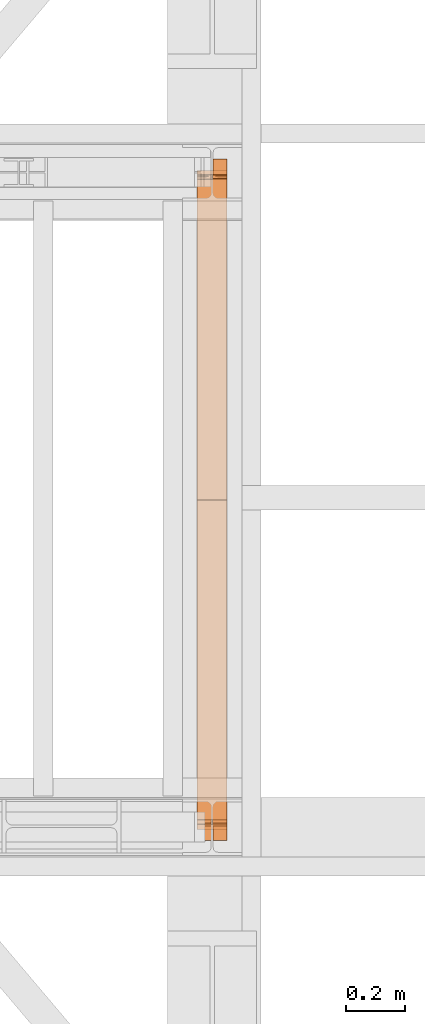
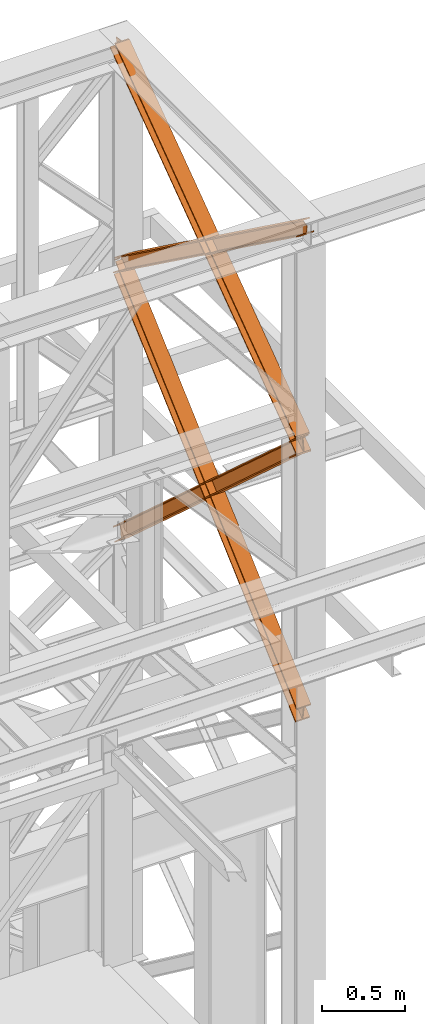
# One storey, part 184 of 208: 4 proxies.
"""IFC2X3 building model written with IfcOpenShell, lengths in millimetres."""

import ifcopenshell
import ifcopenshell.guid

model = None  # the IFC model being written
_history = None  # IfcOwnerHistory: only IFC2X3 demands one
_inside = {}  # id of a spatial element -> (the spatial element, [elements in it])
_under = {}  # id of a project, library or spatial element -> (it, [spatial elements below it])
_declared = {}  # id of a project -> (the project, [libraries it declares])
_typed = {}  # id of a type object -> (the type object, [elements of that type])
_made_of = {}  # id of a material, layer set ... -> (it, [elements and type objects made of it])


def new_model(schema):
    """Start an empty IFC model of exactly this schema.

    Asked for "IFC4X3", IfcOpenShell would pick the latest addendum, in which some entities
    have other attributes; the version numbers below select the first issue.
    IFC2X3 requires an IfcOwnerHistory on every rooted entity: one is made here for all.
    """
    global model, _history
    if schema == "IFC4X3":
        model = ifcopenshell.file(schema_version=(4, 3, 0, 0))
    else:
        model = ifcopenshell.file(schema=schema)
    _inside.clear()
    _under.clear()
    _declared.clear()
    _typed.clear()
    _made_of.clear()
    _history = None
    if model.schema == "IFC2X3":
        org = make("IfcOrganization", Name="unknown")
        user = make(
            "IfcPersonAndOrganization",
            ThePerson=make("IfcPerson", FamilyName="unknown"),
            TheOrganization=org,
        )
        app = make(
            "IfcApplication",
            ApplicationDeveloper=org,
            Version="unknown",
            ApplicationFullName="unknown",
            ApplicationIdentifier="unknown",
        )
        _history = make(
            "IfcOwnerHistory",
            OwningUser=user,
            OwningApplication=app,
            ChangeAction="ADDED",
            CreationDate=0,
        )
    return model


def make(cls, **values):
    """One entity of the class cls with the attributes given. An attribute that is None is left unset."""
    return model.create_entity(
        cls, **{name: value for name, value in values.items() if value is not None}
    )


def entity(cls, *values):
    """Any entity or typed value of the class cls, its attributes in the order of the schema. None: left unset."""
    e = model.create_entity(cls)
    for i, value in enumerate(values):
        if value is not None:
            e[i] = value
    return e


def rooted(cls, **values):
    """An entity with a GlobalId (a new one), such as an element, a storey or a relation."""
    return make(cls, GlobalId=ifcopenshell.guid.new(), OwnerHistory=_history, **values)


def si_unit(unit_type, name, prefix=None):
    """IfcSIUnit, for example si_unit("LENGTHUNIT", "METRE", prefix="MILLI")."""
    return make("IfcSIUnit", UnitType=unit_type, Prefix=prefix, Name=name)


def converted_unit(unit_type, name, factor, base, dimensions=None, offset=None):
    """IfcConversionBasedUnit, such as the inch: factor (a typed value) times the base unit."""
    return make(
        "IfcConversionBasedUnit"
        if offset is None
        else "IfcConversionBasedUnitWithOffset",
        ConversionOffset=offset,
        Dimensions=None
        if dimensions is None
        else entity("IfcDimensionalExponents", *dimensions),
        UnitType=unit_type,
        Name=name,
        ConversionFactor=make(
            "IfcMeasureWithUnit", ValueComponent=factor, UnitComponent=base
        ),
    )


def assignment(units):
    """IfcUnitAssignment: the units of a project."""
    return None if units is None else make("IfcUnitAssignment", Units=units)


def point(xyz):
    """IfcCartesianPoint."""
    return None if xyz is None else make("IfcCartesianPoint", Coordinates=xyz)


def direction(xyz):
    """IfcDirection."""
    return None if xyz is None else make("IfcDirection", DirectionRatios=xyz)


def frame(location, z_axis=None, x_axis=None):
    """IfcAxis2Placement3D, a coordinate frame: its origin and axes. An axis left out is left unset."""
    return make(
        "IfcAxis2Placement3D",
        Location=point(location),
        Axis=direction(z_axis),
        RefDirection=direction(x_axis),
    )


def origin():
    """The frame at (0, 0, 0) with its axes left unset."""
    return frame((0.0, 0.0, 0.0))


def origin_with_axes():
    """The frame at (0, 0, 0) with the z axis (0, 0, 1) and the x axis (1, 0, 0) written out."""
    return frame((0.0, 0.0, 0.0), z_axis=(0.0, 0.0, 1.0), x_axis=(1.0, 0.0, 0.0))


def place(relative_to, where):
    """IfcLocalPlacement: puts the frame where relative to a parent placement (None: the world)."""
    return make(
        "IfcLocalPlacement", PlacementRelTo=relative_to, RelativePlacement=where
    )


def context(
    kind, dimensions, precision=None, world=None, true_north=None, identifier=None
):
    """IfcGeometricRepresentationContext, for example the 3D "Model" context."""
    return make(
        "IfcGeometricRepresentationContext",
        ContextIdentifier=identifier,
        ContextType=kind,
        CoordinateSpaceDimension=dimensions,
        Precision=precision,
        WorldCoordinateSystem=world,
        TrueNorth=true_north,
    )


def subcontext(parent, identifier, kind, view, scale=None):
    """IfcGeometricRepresentationSubContext, for example "Body" below "Model"."""
    return make(
        "IfcGeometricRepresentationSubContext",
        ContextIdentifier=identifier,
        ContextType=kind,
        ParentContext=parent,
        TargetScale=scale,
        TargetView=view,
    )


def project(units=None, contexts=None):
    """IfcProject with its units and contexts."""
    return rooted(
        "IfcProject",
        Name="project",
        RepresentationContexts=contexts,
        UnitsInContext=assignment(units),
    )


def spatial(cls, under=None, at=None, **own):
    """A site, building, storey or space (cls), placed at a placement, below another one or the project."""
    s = rooted(cls, ObjectPlacement=at, **own)
    if under is not None:
        _under.setdefault(under.id(), (under, []))[1].append(s)
    return s


def faces_of(points, faces, orient=None, outer=None):
    """IfcFace entities. A face is a list of loops; a loop is a list of indices into points, from 0.

    orient and outer hold one flag for each loop. By default every Orientation is true, the
    first loop of a face is its IfcFaceOuterBound and the others are IfcFaceBound.
    """
    made = []
    for i, loops in enumerate(faces):
        bounds = []
        for j, loop in enumerate(loops):
            is_outer = j == 0 if outer is None else outer[i][j]
            bounds.append(
                make(
                    "IfcFaceOuterBound" if is_outer else "IfcFaceBound",
                    Bound=make("IfcPolyLoop", Polygon=[points[k] for k in loop]),
                    Orientation=True if orient is None else orient[i][j],
                )
            )
        made.append(make("IfcFace", Bounds=bounds))
    return made


def faceted_brep(points, faces, orient=None, outer=None, voids=None):
    """IfcFacetedBrep: a solid bounded by flat faces; with voids (closed shells), ...WithVoids."""
    shared = [point(p) for p in points]
    hull = make("IfcClosedShell", CfsFaces=faces_of(shared, faces, orient, outer))
    if voids is None:
        return make("IfcFacetedBrep", Outer=hull)
    return make(
        "IfcFacetedBrepWithVoids",
        Outer=hull,
        Voids=[
            make(cls, CfsFaces=faces_of(shared, fs, o, b)) for cls, fs, o, b in voids
        ],
    )


def shape(context_of_items, identifier, shape_type, items):
    """IfcShapeRepresentation: the items that make up one representation, for example the "Body"."""
    return make(
        "IfcShapeRepresentation",
        ContextOfItems=context_of_items,
        RepresentationIdentifier=identifier,
        RepresentationType=shape_type,
        Items=items,
    )


def made_of(thing, what):
    """Note that an element or type object is made of a material, layer set ...; save() writes the relation."""
    if what is not None:
        _made_of.setdefault(what.id(), (what, []))[1].append(thing)
    return thing


def element(
    cls,
    number,
    at=None,
    inside=None,
    cuts=None,
    type_object=None,
    material=None,
    context=None,
    identifier="Body",
    shape_type=None,
    held_by="IfcProductDefinitionShape",
    body=None,
    shapes=None,
    **own,
):
    """One element of the class cls, such as IfcWall. Its Tag is "e" and its number.

    at: its placement. inside: the storey or other place that contains it. cuts: it is an
    opening in that element (IfcRelVoidsElement). A single representation is given by context,
    identifier, shape_type and body (its items); several are given by shapes. held_by: the class
    of the entity that holds the representations. save() writes the other relations.
    """
    e = rooted(cls, Tag="e%d" % number, ObjectPlacement=at, **own)
    if body is not None:
        shapes = [shape(context, identifier, shape_type, body)]
    if shapes is not None:
        e.Representation = make(held_by, Representations=shapes)
    if inside is not None:
        _inside.setdefault(inside.id(), (inside, []))[1].append(e)
    if cuts is not None:
        rooted(
            "IfcRelVoidsElement", RelatingBuildingElement=cuts, RelatedOpeningElement=e
        )
    if type_object is not None:
        _typed.setdefault(type_object.id(), (type_object, []))[1].append(e)
    return made_of(e, material)


def aggregate(whole, parts):
    """IfcRelAggregates: a whole, such as a stair, and the parts it consists of."""
    return rooted("IfcRelAggregates", RelatingObject=whole, RelatedObjects=parts)


def save(model, path):
    """Write the relations noted so far, then the file.

    IfcRelAggregates (storeys below a building ...), IfcRelContainedInSpatialStructure (elements
    in a storey), IfcRelDefinesByType, IfcRelAssociatesMaterial and IfcRelDeclares: one each for
    every whole, place, type object, material and project.
    """
    for whole, parts in _under.values():
        aggregate(whole, parts)
    for where, things in _inside.values():
        rooted(
            "IfcRelContainedInSpatialStructure",
            RelatedElements=things,
            RelatingStructure=where,
        )
    for kind, things in _typed.values():
        rooted("IfcRelDefinesByType", RelatedObjects=things, RelatingType=kind)
    for what, things in _made_of.values():
        rooted("IfcRelAssociatesMaterial", RelatedObjects=things, RelatingMaterial=what)
    for by, libraries in _declared.values():
        rooted("IfcRelDeclares", RelatingContext=by, RelatedDefinitions=libraries)
    model.write(path)


model = new_model("IFC2X3")

# Units and contexts
model_context = context("Model", 3, precision=1e-05, world=origin())
plan_context = context("Plan", 3, precision=1e-05, world=origin())
body_context = subcontext(model_context, "Body", "Model", "MODEL_VIEW")
ifc_project = project(units=[si_unit("LENGTHUNIT", "METRE", prefix="MILLI"), converted_unit("PLANEANGLEUNIT", "DEGREE", entity("IfcPlaneAngleMeasure", 0.0174532925199433), si_unit("PLANEANGLEUNIT", "RADIAN"), dimensions=[0, 0, 0, 0, 0, 0, 0]), si_unit("AREAUNIT", "SQUARE_METRE"), si_unit("VOLUMEUNIT", "CUBIC_METRE")], contexts=[model_context, plan_context])

# Building, storey
building_placement = place(None, origin())
building = spatial("IfcBuilding", under=ifc_project, at=building_placement, CompositionType="COMPLEX")
storey_placement = place(building_placement, origin_with_axes())
storey = spatial("IfcBuildingStorey", under=building, at=storey_placement, Name="Geschoss", CompositionType="ELEMENT")

# Proxies
proxy_1_placement = place(storey_placement, frame((8742.709402308908, -16015.63876149258, 10682.68948145022), z_axis=(0.0, 0.0, 1.0), x_axis=(1.0, 0.0, 0.0)))
element("IfcBuildingElementProxy", 1, at=proxy_1_placement, inside=storey, context=body_context, shape_type="Brep", body=[
    faceted_brep([(100.0210796676656, 2245.689626284609, 118.5389832593155), (100.1143745484151, 56.20017042807194, 1708.580236273849), (100.1148393871226, 67.43957130666058, 1710.120789741106), (100.0220869572258, 2244.212677303514, 129.3143453983157), (100.0220869572258, 2244.212677303514, 129.3143453983157), (100.1148393871226, 67.43957130666058, 1710.120789741106), (0.1148394121519232, 67.45274636205431, 1710.122490249456), (0.02208754364073684, 2244.212677303513, 129.3256138365559), (0.02208754364073684, 2244.212677303513, 129.3256138365559), (0.1148394121519232, 67.45274636205431, 1710.122490249456), (0.1143745734407275, 56.21334548348023, 1708.581936782199), (0.02108025408597314, 2245.689626284609, 118.5502516975485), (0.02108025408597314, 2245.689626284609, 118.5502516975485), (0.1143745734407275, 56.21334548348023, 1708.581936782199), (47.61437456155181, 56.20708733215906, 1708.581129040735), (47.52107997553685, 2245.689626284611, 118.5448991893809), (47.52107997553685, 2245.689626284611, 118.5448991893809), (47.61437456155181, 56.20708733215906, 1708.581129040735), (47.61205046476789, 0.010082544398756, 1700.878361650326), (47.60701710203466, 7.394829104428936, 1647.001538883871), (47.51100702250551, 2260.459116064767, 10.79127802407129), (47.51100702250551, 2260.459116064767, 10.79127802407129), (47.60701710203466, 7.394829104428936, 1647.001538883871), (0.107017380585603, 7.394829104430755, 1647.006891392024), (0.01100730106008996, 2260.459116064769, 10.79663053222066), (0.01100730106008996, 2260.459116064769, 10.79663053222066), (0.107017380585603, 7.394829104430755, 1647.006891392024), (0.1060107062494353, 8.871778415476001, 1636.231526845748), (0.01000000000021828, 2261.936065039698, 0.02126843821861257), (0.01000000000021828, 2261.936065039698, 0.02126843821861257), (0.1060107062494353, 8.871778415476001, 1636.231526845748), (100.1060101198273, 8.871778415472363, 1636.220258407533), (100.0099994135744, 2261.936065039694, 0.01000000000021828), (100.0099994135744, 2261.936065039694, 0.01000000000021828), (100.1060101198273, 8.871778415472363, 1636.220258407533), (100.1070167941634, 7.394829104425298, 1646.995622953813), (100.0110067146379, 2260.459116064765, 10.78536209401318), (100.0110067146379, 2260.459116064765, 10.78536209401318), (100.1070167941634, 7.394829104425298, 1646.995622953813), (52.60701707271619, 7.394829104428936, 1647.000975461962), (52.51100699318704, 2260.459116064767, 10.79071460216255), (52.51100699318704, 2260.459116064767, 10.79071460216255), (52.60701707271619, 7.394829104428936, 1647.000975461962), (52.61205048734519, 0.01000000000021828, 1700.878355604191), (52.61437456030035, 56.20642857939311, 1708.581044015316), (52.52107994621292, 2245.689626284609, 118.5443357674758), (52.52107994621292, 2245.689626284609, 118.5443357674758), (52.61437456030035, 56.20642857939311, 1708.581044015316), (100.1143745484151, 56.20017042807194, 1708.580236273849), (100.0210796676656, 2245.689626284609, 118.5389832593155), (100.1143745484151, 56.20017042807194, 1708.580236273849), (52.61437456030035, 56.20642857939311, 1708.581044015316), (52.61205048734519, 0.01000000000021828, 1700.878355604191), (47.61205046476789, 0.010082544398756, 1700.878361650326), (47.61437456155181, 56.20708733215906, 1708.581129040735), (0.1143745734407275, 56.21334548348023, 1708.581936782199), (0.1148394121519232, 67.45274636205431, 1710.122490249456), (100.1148393871226, 67.43957130666058, 1710.120789741106), (47.61205046476789, 0.010082544398756, 1700.878361650326), (52.61205048734519, 0.01000000000021828, 1700.878355604191), (52.60701707271619, 7.394829104428936, 1647.000975461962), (100.1070167941634, 7.394829104425298, 1646.995622953813), (100.1060101198273, 8.871778415472363, 1636.220258407533), (0.1060107062494353, 8.871778415476001, 1636.231526845748), (0.107017380585603, 7.394829104430755, 1647.006891392024), (47.60701710203466, 7.394829104428936, 1647.001538883871), (100.0220869572258, 2244.212677303514, 129.3143453983157), (0.02208754364073684, 2244.212677303513, 129.3256138365559), (0.02108025408597314, 2245.689626284609, 118.5502516975485), (47.52107997553685, 2245.689626284611, 118.5448991893809), (47.51100702250551, 2260.459116064767, 10.79127802407129), (0.01100730106008996, 2260.459116064769, 10.79663053222066), (0.01000000000021828, 2261.936065039698, 0.02126843821861257), (100.0099994135744, 2261.936065039694, 0.01000000000021828), (100.0110067146379, 2260.459116064765, 10.78536209401318), (52.51100699318704, 2260.459116064767, 10.79071460216255), (52.52107994621292, 2245.689626284609, 118.5443357674758), (100.0210796676656, 2245.689626284609, 118.5389832593155)], [[[0, 1, 2, 3]], [[4, 5, 6, 7]], [[8, 9, 10, 11]], [[12, 13, 14, 15]], [[16, 17, 18, 19, 20]], [[21, 22, 23, 24]], [[25, 26, 27, 28]], [[29, 30, 31, 32]], [[33, 34, 35, 36]], [[37, 38, 39, 40]], [[41, 42, 43, 44, 45]], [[46, 47, 48, 49]], [[50, 51, 52, 53, 54, 55, 56, 57]], [[58, 59, 60, 61, 62, 63, 64, 65]], [[66, 67, 68, 69, 70, 71, 72, 73, 74, 75, 76, 77]]], orient=[[False], [False], [False], [False], [False], [False], [False], [False], [False], [False], [False], [False], [False], [False], [False]]),
])
proxy_2_placement = place(storey_placement, frame((8742.729181833696, -15971.44366069647, 10682.68296591904), z_axis=(0.0, 0.0, 1.0), x_axis=(1.0, 0.0, 0.0)))
element("IfcBuildingElementProxy", 2, at=proxy_2_placement, inside=storey, context=body_context, shape_type="Brep", body=[
    faceted_brep([(100.021793255235, 17.74853331263148, 129.3267546407205), (100.0912677831893, 2190.182945540866, 1706.987836358048), (100.090692227559, 2201.421092011329, 1705.446286432978), (100.0208104383455, 16.27032220023102, 118.5503583986774), (0.0217938701462117, 17.74853331263148, 129.3386776252864), (0.09126795233351004, 2190.169006714281, 1706.989636715169), (100.0912677831893, 2190.182945540866, 1706.987836358048), (100.021793255235, 17.74853331263148, 129.3267546407205), (0.02081105325669341, 16.27032220022738, 118.5622813832288), (0.09069239670134266, 2201.407153184735, 1705.448086790095), (0.09126795233351004, 2190.169006714281, 1706.989636715169), (0.0217938701462117, 17.74853331263148, 129.3386776252864), (47.52081076117429, 16.2703222002292, 118.5566179655598), (47.5906923163584, 2201.413774127363, 1705.447231620465), (0.09069239670134266, 2201.407153184735, 1705.448086790095), (0.02081105325669341, 16.27032220022738, 118.5622813832288), (47.51098253605596, 1.488211106367089, 10.79265576491343), (47.58304941302595, 2254.773823250514, 1647.169314498546), (47.58760831104883, 2261.634760381639, 1697.186647271237), (47.5906923163584, 2201.413774127363, 1705.447231620465), (47.52081076117429, 16.2703222002292, 118.5566179655598), (0.01098282814018603, 1.488211106363451, 10.79831918255331), (0.08304970511017018, 2254.773823250511, 1647.174977916204), (47.58304941302595, 2254.773823250514, 1647.169314498546), (47.51098253605596, 1.488211106367089, 10.79265576491343), (0.00999999999839929, 0.01000000000021828, 0.02192298452973773), (0.08206748974043876, 2253.295611815232, 1636.398579320261), (0.08304970511017018, 2254.773823250511, 1647.174977916204), (0.01098282814018603, 1.488211106363451, 10.79831918255331), (100.0099993850818, 0.01000000000567525, 0.01000000000021828), (100.0820668748274, 2253.29561181524, 1636.386656335728), (0.08206748974043876, 2253.295611815232, 1636.398579320261), (0.00999999999839929, 0.01000000000021828, 0.02192298452973773), (100.0109822132272, 1.488211106370727, 10.78639619803107), (100.0830490901899, 2254.773823250516, 1647.163054931671), (100.0820668748274, 2253.29561181524, 1636.386656335728), (100.0099993850818, 0.01000000000567525, 0.01000000000021828), (52.51098250530413, 1.48821110636527, 10.79205961566731), (52.58304938227775, 2254.773823250514, 1647.168718349318), (100.0830490901899, 2254.773823250516, 1647.163054931671), (100.0109822132272, 1.488211106370727, 10.78639619803107), (52.52081073042609, 16.27032220022738, 118.5560218163319), (52.59069230790192, 2201.414471068691, 1705.447141602608), (52.58760833413544, 2261.634841397497, 1697.186641740611), (52.58304938227775, 2254.773823250514, 1647.168718349318), (52.51098250530413, 1.48821110636527, 10.79205961566731), (100.0208104383455, 16.27032220023102, 118.5503583986774), (100.090692227559, 2201.421092011329, 1705.446286432978), (52.59069230790192, 2201.414471068691, 1705.447141602608), (52.52081073042609, 16.27032220022738, 118.5560218163319), (100.0912677831893, 2190.182945540866, 1706.987836358048), (0.09126795233351004, 2190.169006714281, 1706.989636715169), (0.09069239670134266, 2201.407153184735, 1705.448086790095), (47.5906923163584, 2201.413774127363, 1705.447231620465), (47.58760831104883, 2261.634760381639, 1697.186647271237), (52.58760833413544, 2261.634841397497, 1697.186641740611), (52.59069230790192, 2201.414471068691, 1705.447141602608), (100.090692227559, 2201.421092011329, 1705.446286432978), (47.58760831104883, 2261.634760381639, 1697.186647271237), (47.58304941302595, 2254.773823250514, 1647.169314498546), (0.08304970511017018, 2254.773823250511, 1647.174977916204), (0.08206748974043876, 2253.295611815232, 1636.398579320261), (100.0820668748274, 2253.29561181524, 1636.386656335728), (100.0830490901899, 2254.773823250516, 1647.163054931671), (52.58304938227775, 2254.773823250514, 1647.168718349318), (52.58760833413544, 2261.634841397497, 1697.186641740611), (100.0208104383455, 16.27032220023102, 118.5503583986774), (52.52081073042609, 16.27032220022738, 118.5560218163319), (52.51098250530413, 1.48821110636527, 10.79205961566731), (100.0109822132272, 1.488211106370727, 10.78639619803107), (100.0099993850818, 0.01000000000567525, 0.01000000000021828), (0.00999999999839929, 0.01000000000021828, 0.02192298452973773), (0.01098282814018603, 1.488211106363451, 10.79831918255331), (47.51098253605596, 1.488211106367089, 10.79265576491343), (47.52081076117429, 16.2703222002292, 118.5566179655598), (0.02081105325669341, 16.27032220022738, 118.5622813832288), (0.0217938701462117, 17.74853331263148, 129.3386776252864), (100.021793255235, 17.74853331263148, 129.3267546407205)], [[[0, 1, 2, 3]], [[4, 5, 6, 7]], [[8, 9, 10, 11]], [[12, 13, 14, 15]], [[16, 17, 18, 19, 20]], [[21, 22, 23, 24]], [[25, 26, 27, 28]], [[29, 30, 31, 32]], [[33, 34, 35, 36]], [[37, 38, 39, 40]], [[41, 42, 43, 44, 45]], [[46, 47, 48, 49]], [[50, 51, 52, 53, 54, 55, 56, 57]], [[58, 59, 60, 61, 62, 63, 64, 65]], [[66, 67, 68, 69, 70, 71, 72, 73, 74, 75, 76, 77]]], orient=[[False], [False], [False], [False], [False], [False], [False], [False], [False], [False], [False], [False], [False], [False], [False]]),
])
proxy_3_placement = place(storey_placement, frame((8742.676947659522, -15970.94025142175, 8709.664099392032), z_axis=(0.0, 0.0, 1.0), x_axis=(1.0, 0.0, 0.0)))
element("IfcBuildingElementProxy", 3, at=proxy_3_placement, inside=storey, context=body_context, shape_type="Brep", body=[
    faceted_brep([(100.0233874223195, 2202.524047252906, 1969.026231437971), (100.204135948361, 16.74193427489081, 0.02100513656296243), (100.2031119106669, 15.34760641933463, 9.331797992270367), (100.0223627570795, 2201.129719715085, 1978.337022171885), (0.02338802788472094, 2202.524047252906, 1969.015226301408), (0.2041365539262188, 16.74193427489081, 0.01000000000021828), (100.204135948361, 16.74193427489081, 0.02100513656296243), (100.0233874223195, 2202.524047252906, 1969.026231437971), (0.02236336264650163, 2201.129719715083, 1978.32601703533), (0.2031125162320677, 15.34760641933463, 9.320792855700347), (0.2041365539262188, 16.74193427489081, 0.01000000000021828), (0.02338802788472094, 2202.524047252906, 1969.015226301408), (47.52236307500243, 2201.129719715083, 1978.331244475192), (47.703112228588, 15.34760641933463, 9.326020295562557), (0.2031125162320677, 15.34760641933463, 9.320792855700347), (0.02236336264650163, 2201.129719715083, 1978.32601703533), (47.51211642258568, 2187.186444336861, 2071.439151814395), (47.69287186516885, 1.404327856926102, 102.4339488982641), (47.703112228588, 15.34760641933463, 9.326020295562557), (47.52236307500243, 2201.129719715083, 1978.331244475192), (0.0110594602265337, 2197.850904391578, 2081.040801967907), (0.01123343514518638, 2196.096022801514, 2079.459950003524), (29.30670605184969, 2196.096022801514, 2079.463174010305), (38.62248918838486, 2197.75725418804, 2080.960688188874), (38.72759933923771, 2197.85090439158, 2081.04506277602), (47.51211642258568, 2187.186444336861, 2071.439151814395), (0.0121167102297477, 2187.186444336861, 2071.433924374533), (0.1928721528147435, 1.404327856924283, 102.4287214583947), (47.69287186516885, 1.404327856926102, 102.4339488982641), (0.01000000000021828, 2196.807553171771, 2090.667763094707), (0.01020876990332909, 2194.701695263691, 2088.770740737438), (0.01123343514518638, 2196.096022801514, 2079.459950003524), (0.0110594602265337, 2197.850904391578, 2081.040801967907), (0.0121167102297477, 2187.186444336861, 2071.433924374533), (0.01109204498970939, 2185.792116799039, 2080.744715108447), (0.1918481178254297, 0.00999999999839929, 111.7395143232407), (0.1928721528147435, 1.404327856924283, 102.4287214583947), (100.0099993944386, 2196.80755317177, 2090.67876823127), (100.0102081643418, 2194.701695263691, 2088.781745874001), (71.80672165016404, 2194.701695263691, 2088.778642041782), (62.49088072881023, 2196.362926650216, 2090.274105784663), (61.99182992716487, 2196.80755317177, 2090.674584279774), (0.01109204498970939, 2185.792116799039, 2080.744715108447), (100.0110914394281, 2185.792116799039, 2080.755720245017), (100.1918475122639, 0.00999999999839929, 111.7505194598034), (0.1918481178254297, 0.00999999999839929, 111.7395143232407), (0.01020876990332909, 2194.701695263691, 2088.770740737438), (0.01000000000021828, 2196.807553171771, 2090.667763094707), (39.12153594998199, 2196.807553171771, 2090.672067372672), (38.62250061437408, 2196.362926650216, 2090.271479036817), (29.3067174778389, 2194.701695263691, 2088.773964858256), (100.0110588546631, 2197.85090439158, 2081.051807104463), (100.01123282958, 2196.096022801514, 2079.470955140079), (100.0102081643418, 2194.701695263691, 2088.781745874001), (100.0099993944386, 2196.80755317177, 2090.67876823127), (100.0110914394281, 2185.792116799039, 2080.755720245017), (100.0121161046682, 2187.186444336861, 2071.444929511088), (100.1928715472459, 1.404327856926102, 102.4397265949574), (100.1918475122639, 0.00999999999839929, 111.7505194598034), (52.5121163923086, 2187.186444336861, 2071.439702071226), (52.69287183489359, 1.404327856924283, 102.4344991550879), (100.1928715472459, 1.404327856926102, 102.4397265949574), (100.0121161046682, 2187.186444336861, 2071.444929511088), (71.80671022417482, 2196.096022801516, 2079.467851193831), (100.01123282958, 2196.096022801514, 2079.470955140079), (100.0110588546631, 2197.85090439158, 2081.051807104463), (62.38575589440734, 2197.85090439158, 2081.047666388475), (62.49086930282101, 2197.75725418804, 2080.963314936713), (52.52236304472172, 2201.129719715083, 1978.331794732023), (52.7031121983091, 15.34760641933463, 9.326570552393605), (52.69287183489359, 1.404327856924283, 102.4344991550879), (52.5121163923086, 2187.186444336861, 2071.439702071226), (100.0223627570795, 2201.129719715085, 1978.337022171885), (100.2031119106669, 15.34760641933463, 9.331797992270367), (52.7031121983091, 15.34760641933463, 9.326570552393605), (52.52236304472172, 2201.129719715083, 1978.331794732023), (62.38575589440734, 2197.85090439158, 2081.047666388475), (100.0110588546631, 2197.85090439158, 2081.051807104463), (100.0099993944386, 2196.80755317177, 2090.67876823127), (61.99182992716487, 2196.80755317177, 2090.674584279774), (39.12153594998199, 2196.807553171771, 2090.672067372672), (0.01000000000021828, 2196.807553171771, 2090.667763094707), (0.0110594602265337, 2197.850904391578, 2081.040801967907), (38.72759933923771, 2197.85090439158, 2081.04506277602), (62.49086930282101, 2197.75725418804, 2080.963314936713), (62.38575589440734, 2197.85090439158, 2081.047666388475), (61.99182992716487, 2196.80755317177, 2090.674584279774), (62.49088072881023, 2196.362926650216, 2090.274105784663), (62.49088072881023, 2196.362926650216, 2090.274105784663), (71.80672165016404, 2194.701695263691, 2088.778642041782), (71.80671022417482, 2196.096022801516, 2079.467851193831), (62.49086930282101, 2197.75725418804, 2080.963314936713), (71.80672165016404, 2194.701695263691, 2088.778642041782), (100.0102081643418, 2194.701695263691, 2088.781745874001), (100.01123282958, 2196.096022801514, 2079.470955140079), (71.80671022417482, 2196.096022801516, 2079.467851193831), (100.0223627570795, 2201.129719715085, 1978.337022171885), (52.52236304472172, 2201.129719715083, 1978.331794732023), (52.5121163923086, 2187.186444336861, 2071.439702071226), (100.0121161046682, 2187.186444336861, 2071.444929511088), (100.0110914394281, 2185.792116799039, 2080.755720245017), (0.01109204498970939, 2185.792116799039, 2080.744715108447), (0.0121167102297477, 2187.186444336861, 2071.433924374533), (47.51211642258568, 2187.186444336861, 2071.439151814395), (47.52236307500243, 2201.129719715083, 1978.331244475192), (0.02236336264650163, 2201.129719715083, 1978.32601703533), (0.02338802788472094, 2202.524047252906, 1969.015226301408), (100.0233874223195, 2202.524047252906, 1969.026231437971), (29.30670605184969, 2196.096022801514, 2079.463174010305), (0.01123343514518638, 2196.096022801514, 2079.459950003524), (0.01020876990332909, 2194.701695263691, 2088.770740737438), (29.3067174778389, 2194.701695263691, 2088.773964858256), (29.3067174778389, 2194.701695263691, 2088.773964858256), (38.62250061437408, 2196.362926650216, 2090.271479036817), (38.62248918838486, 2197.75725418804, 2080.960688188874), (29.30670605184969, 2196.096022801514, 2079.463174010305), (38.62250061437408, 2196.362926650216, 2090.271479036817), (39.12153594998199, 2196.807553171771, 2090.672067372672), (38.72759933923771, 2197.85090439158, 2081.04506277602), (38.62248918838486, 2197.75725418804, 2080.960688188874), (100.204135948361, 16.74193427489081, 0.02100513656296243), (0.2041365539262188, 16.74193427489081, 0.01000000000021828), (0.2031125162320677, 15.34760641933463, 9.320792855700347), (47.703112228588, 15.34760641933463, 9.326020295562557), (47.69287186516885, 1.404327856926102, 102.4339488982641), (0.1928721528147435, 1.404327856924283, 102.4287214583947), (0.1918481178254297, 0.00999999999839929, 111.7395143232407), (100.1918475122639, 0.00999999999839929, 111.7505194598034), (100.1928715472459, 1.404327856926102, 102.4397265949574), (52.69287183489359, 1.404327856924283, 102.4344991550879), (52.7031121983091, 15.34760641933463, 9.326570552393605), (100.2031119106669, 15.34760641933463, 9.331797992270367)], [[[0, 1, 2, 3]], [[4, 5, 6, 7]], [[8, 9, 10, 11]], [[12, 13, 14, 15]], [[16, 17, 18, 19]], [[20, 21, 22, 23, 24]], [[25, 26, 27, 28]], [[29, 30, 31, 32]], [[33, 34, 35, 36]], [[37, 38, 39, 40, 41]], [[42, 43, 44, 45]], [[46, 47, 48, 49, 50]], [[51, 52, 53, 54]], [[55, 56, 57, 58]], [[59, 60, 61, 62]], [[63, 64, 65, 66, 67]], [[68, 69, 70, 71]], [[72, 73, 74, 75]], [[76, 77, 78, 79]], [[80, 81, 82, 83]], [[84, 85, 86, 87]], [[88, 89, 90, 91]], [[92, 93, 94, 95]], [[96, 97, 98, 99, 100, 101, 102, 103, 104, 105, 106, 107]], [[108, 109, 110, 111]], [[112, 113, 114, 115]], [[116, 117, 118, 119]], [[120, 121, 122, 123, 124, 125, 126, 127, 128, 129, 130, 131]]], orient=[[False], [False], [False], [False], [False], [False], [False], [False], [False], [False], [False], [False], [False], [False], [False], [False], [False], [False], [False], [False], [False], [False], [False], [False], [False], [False], [False], [False]]),
])
proxy_4_placement = place(storey_placement, frame((8742.73408746112, -15954.28145682049, 8709.631705441292), z_axis=(0.0, 0.0, 1.0), x_axis=(1.0, 0.0, 0.0)))
element("IfcBuildingElementProxy", 4, at=proxy_4_placement, inside=storey, context=body_context, shape_type="Brep", body=[
    faceted_brep([(100.0202537490113, 1.404418357440591, 1976.169685278082), (100.1537894349167, 2184.74959498962, 9.331916248220296), (100.1547211341531, 2183.35672227913, 0.0197810693334759), (100.0211859525844, 0.01154596052219858, 1966.857552195595), (100.0211859525844, 0.01154596052219858, 1966.857552195595), (100.1547211341531, 2183.35672227913, 0.0197810693334759), (0.1547216244507581, 2183.355176318608, 0.01000000000021828), (0.02118644288202631, 0.01000000000021828, 1966.847771126266), (0.02118644288202631, 0.01000000000021828, 1966.847771126266), (0.1547216244507581, 2183.355176318608, 0.01000000000021828), (0.1537899252161878, 2184.748049029098, 9.322135178887038), (0.02025423930899706, 1.40287239691861, 1976.159904208749), (0.02025423930899706, 1.40287239691861, 1976.159904208749), (0.1537899252161878, 2184.748049029098, 9.322135178887038), (47.65378969232734, 2184.748783360346, 9.326781186826338), (47.52025400642015, 1.403606728164959, 1976.164550216681), (47.52025400642015, 1.403606728164959, 1976.164550216681), (47.65378969232734, 2184.748783360346, 9.326781186826338), (47.64447271073732, 2198.677510471935, 102.4481330204089), (47.51093197068258, 15.33233069734524, 2069.285881041526), (47.51093197068258, 15.33233069734524, 2069.285881041526), (47.64447271073732, 2198.677510471935, 102.4481330204089), (0.1444729436279886, 2198.676776140686, 102.4434870124769), (0.01093220357506652, 15.33159636609526, 2069.281235033586), (0.01093220357506652, 15.33159636609526, 2069.281235033586), (0.1444729436279886, 2198.676776140686, 102.4434870124769), (0.1435412465452828, 2200.069648852516, 111.7556222003168), (0.01000000000021828, 16.72446876301547, 2078.593368116077), (0.01000000000021828, 16.72446876301547, 2078.593368116077), (0.1435412465452828, 2200.069648852516, 111.7556222003168), (100.1435407562476, 2200.071194813039, 111.7654032696537), (100.0099995097044, 16.72601472353745, 2078.603149185414), (100.0099995097044, 16.72601472353745, 2078.603149185414), (100.1435407562476, 2200.071194813039, 111.7654032696537), (100.1444724533303, 2198.67832210121, 102.4532680818102), (100.0109317132756, 15.33314232661905, 2069.29101610293), (100.0109317132756, 15.33314232661905, 2069.29101610293), (100.1444724533303, 2198.67832210121, 102.4532680818102), (52.64447268622098, 2198.677587769962, 102.4486220738781), (52.51093194616988, 15.33240799537089, 2069.286370094991), (52.51093194616988, 15.33240799537089, 2069.286370094991), (52.64447268622098, 2198.677587769962, 102.4486220738781), (52.653789667811, 2184.748860658372, 9.327270240288271), (52.52025398190563, 1.403684026192423, 1976.165039270154), (52.52025398190563, 1.403684026192423, 1976.165039270154), (52.653789667811, 2184.748860658372, 9.327270240288271), (100.1537894349167, 2184.74959498962, 9.331916248220296), (100.0202537490113, 1.404418357440591, 1976.169685278082), (100.0211859525844, 0.01154596052219858, 1966.857552195595), (0.02118644288202631, 0.01000000000021828, 1966.847771126266), (0.02025423930899706, 1.40287239691861, 1976.159904208749), (47.52025400642015, 1.403606728164959, 1976.164550216681), (47.51093197068258, 15.33233069734524, 2069.285881041526), (0.01093220357506652, 15.33159636609526, 2069.281235033586), (0.01000000000021828, 16.72446876301547, 2078.593368116077), (100.0099995097044, 16.72601472353745, 2078.603149185414), (100.0109317132756, 15.33314232661905, 2069.29101610293), (52.51093194616988, 15.33240799537089, 2069.286370094991), (52.52025398190563, 1.403684026192423, 1976.165039270154), (100.0202537490113, 1.404418357440591, 1976.169685278082), (100.1537894349167, 2184.74959498962, 9.331916248220296), (52.653789667811, 2184.748860658372, 9.327270240288271), (52.64447268622098, 2198.677587769962, 102.4486220738781), (100.1444724533303, 2198.67832210121, 102.4532680818102), (100.1435407562476, 2200.071194813039, 111.7654032696537), (0.1435412465452828, 2200.069648852516, 111.7556222003168), (0.1444729436279886, 2198.676776140686, 102.4434870124769), (47.64447271073732, 2198.677510471935, 102.4481330204089), (47.65378969232734, 2184.748783360346, 9.326781186826338), (0.1537899252161878, 2184.748049029098, 9.322135178887038), (0.1547216244507581, 2183.355176318608, 0.01000000000021828), (100.1547211341531, 2183.35672227913, 0.0197810693334759)], [[[0, 1, 2, 3]], [[4, 5, 6, 7]], [[8, 9, 10, 11]], [[12, 13, 14, 15]], [[16, 17, 18, 19]], [[20, 21, 22, 23]], [[24, 25, 26, 27]], [[28, 29, 30, 31]], [[32, 33, 34, 35]], [[36, 37, 38, 39]], [[40, 41, 42, 43]], [[44, 45, 46, 47]], [[48, 49, 50, 51, 52, 53, 54, 55, 56, 57, 58, 59]], [[60, 61, 62, 63, 64, 65, 66, 67, 68, 69, 70, 71]]], orient=[[False], [False], [False], [False], [False], [False], [False], [False], [False], [False], [False], [False], [False], [False]]),
])

save(model, "model.ifc")
